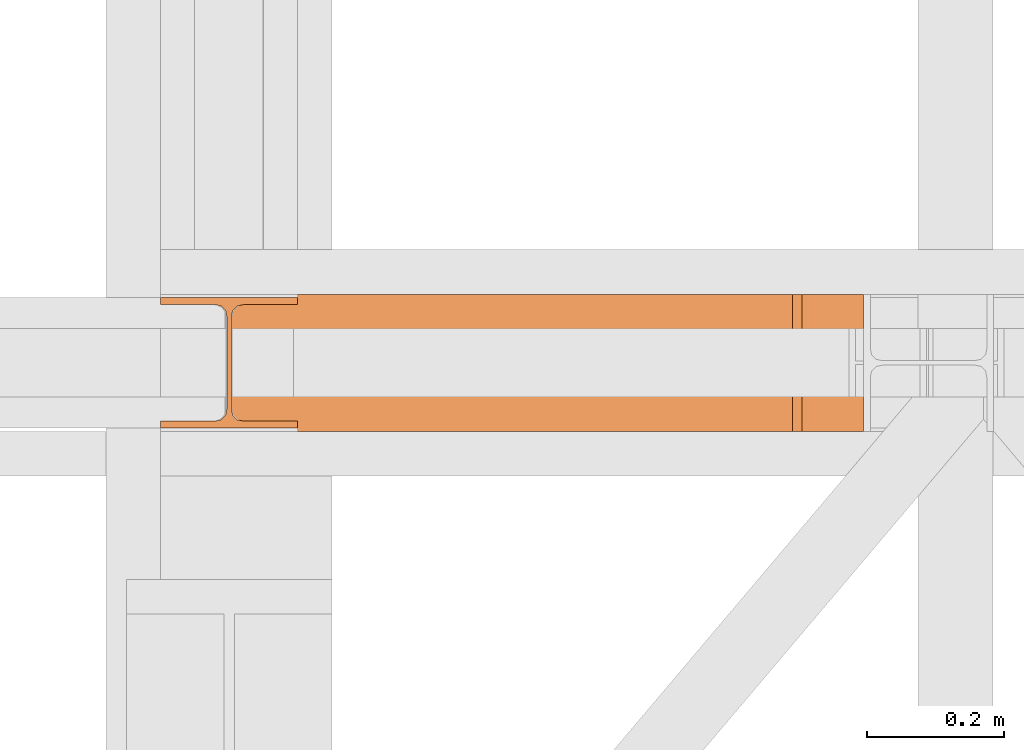
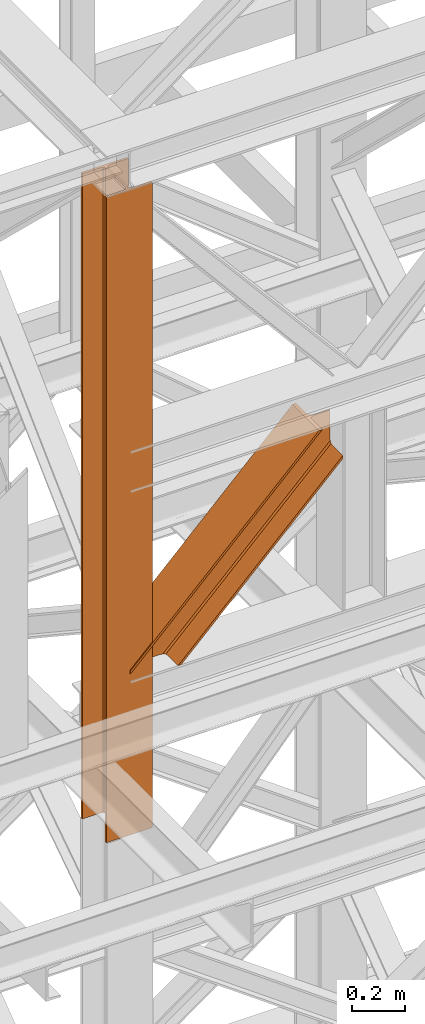
# One storey, part 107 of 208: 2 proxies.
"""IFC2X3 building model written with IfcOpenShell, lengths in millimetres."""

from ifc_helpers import new_model, entity, si_unit, converted_unit, frame, origin, origin_with_axes, place, context, subcontext, project, spatial, faceted_brep, element, save


model = new_model("IFC2X3")

# Units and contexts
model_context = context("Model", 3, precision=1e-05, world=origin())
plan_context = context("Plan", 3, precision=1e-05, world=origin())
body_context = subcontext(model_context, "Body", "Model", "MODEL_VIEW")
ifc_project = project(units=[si_unit("LENGTHUNIT", "METRE", prefix="MILLI"), converted_unit("PLANEANGLEUNIT", "DEGREE", entity("IfcPlaneAngleMeasure", 0.0174532925199433), si_unit("PLANEANGLEUNIT", "RADIAN"), dimensions=[0, 0, 0, 0, 0, 0, 0]), si_unit("AREAUNIT", "SQUARE_METRE"), si_unit("VOLUMEUNIT", "CUBIC_METRE")], contexts=[model_context, plan_context])

# Building, storey
building_placement = place(None, origin())
building = spatial("IfcBuilding", under=ifc_project, at=building_placement, CompositionType="COMPLEX")
storey_placement = place(building_placement, origin_with_axes())
storey = spatial("IfcBuildingStorey", under=building, at=storey_placement, Name="Geschoss", CompositionType="ELEMENT")

# Proxies
proxy_1_placement = place(storey_placement, frame((-4.776652347532718, -16062.574391808, 9993.99004617683), z_axis=(0.0, 0.0, 1.0), x_axis=(1.0, 0.0, 0.0)))
element("IfcBuildingElementProxy", 1, at=proxy_1_placement, inside=storey, context=body_context, shape_type="Brep", body=[
    faceted_brep([(220.8913571195315, 0.01000000000021828, 0.01000000000567525), (923.0416068691063, 0.01000000000021828, 700.1727607699759), (923.0416068691072, 200.0100029802325, 700.172760769974), (220.8913571195315, 200.0100029802325, 0.01000000000567525), (220.8913571195315, 200.0100029802325, 0.01000000000567525), (923.0416068691072, 200.0100029802325, 700.172760769974), (923.0416068691063, 200.0100029802325, 714.2845694178923), (206.7394905511699, 200.0100029802325, 0.01000000000385626), (206.7394905511699, 200.0100029802325, 0.01000000000385626), (923.0416068691063, 200.0100029802325, 714.2845694178923), (923.0416068691063, 121.2600035762789, 714.2845799320112), (206.7394800072068, 121.2600035762789, 0.01000000000385626), (206.7394800072068, 121.2600035762789, 0.01000000000385626), (923.0416068691063, 121.2600035762789, 714.2845799320112), (923.0416068691063, 111.9441915473344, 716.9157907731915), (204.1008001847456, 111.9441915473344, 0.01000000000203727), (204.1008001847456, 111.9441915473344, 0.01000000000203727), (923.0416068691063, 111.9441915473344, 716.9157907731915), (923.0416068691063, 105.1245498640838, 726.5395426003979), (194.4497302798461, 105.1245498640838, 0.01000000000385626), (194.4497302798461, 105.1245498640838, 0.01000000000385626), (923.0416068691063, 105.1245498640838, 726.5395426003979), (923.0416068691063, 103.2600015571716, 739.685839703905), (181.2661159665693, 103.2600015571716, 0.01000000000385626), (181.2661159665693, 103.2600015571716, 0.01000000000385626), (923.0416068691063, 103.2600015571716, 739.685839703905), (923.0416068691063, 103.2600015571716, 865.0100000000039), (859.0864467289928, 103.2600015571716, 865.0100000000039), (0.009999999999990905, 103.2600015571716, 8.365233628765054), (0.009999999999990905, 103.2600015571716, 0.01000000000385626), (0.009999999999990905, 103.2600015571716, 8.365233628765054), (859.0864467289928, 103.2600015571716, 865.0100000000039), (845.9028324157168, 105.1245498640838, 865.0100000000039), (0.009999999999990905, 105.1245498640838, 21.51153073227761), (0.009999999999990905, 105.1245498640838, 21.51153073227761), (845.9028324157168, 105.1245498640838, 865.0100000000039), (836.2517625108146, 111.9441915473344, 865.0100000000039), (0.009999999999990905, 111.9441915473344, 31.13528255948222), (0.009999999999990905, 111.9441915473344, 31.13528255948222), (836.2517625108146, 111.9441915473344, 865.0100000000039), (833.6130826883589, 121.2600035762789, 865.0100000000057), (0.009999999999990905, 121.2600035762789, 33.76649340066069), (0.009999999999990905, 121.2600035762789, 33.76649340066069), (833.6130826883589, 121.2600035762789, 865.0100000000057), (833.6130826883589, 200.0100029802325, 865.0100000000039), (0.009999999999990905, 200.0100029802325, 33.76649340066069), (0.009999999999990905, 200.0100029802325, 33.76649340066069), (833.6130826883589, 200.0100029802325, 865.0100000000039), (819.4612161199955, 200.0100029802325, 865.0100000000039), (0.009999999999990905, 200.0100029802325, 47.87830204857892), (0.009999999999990905, 200.0100029802325, 47.87830204857892), (819.4612161199955, 200.0100029802325, 865.0100000000039), (819.4612161199973, 0.01000000000021828, 865.0100000000057), (0.009999999999990905, 0.01000000000021828, 47.8783020485771), (0.009999999999990905, 0.01000000000021828, 47.8783020485771), (819.4612161199973, 0.01000000000021828, 865.0100000000057), (833.6130826883589, 0.01000000000021828, 865.0100000000039), (0.009999999999990905, 0.01000000000021828, 33.76649340066069), (0.009999999999990905, 0.01000000000021828, 33.76649340066069), (833.6130826883589, 0.01000000000021828, 865.0100000000039), (833.6130826883589, 78.75999940395377, 865.0100000000039), (0.009999999999990905, 78.75999940395377, 33.76649340066069), (0.009999999999990905, 78.75999940395377, 33.76649340066069), (833.6130826883589, 78.75999940395377, 865.0100000000039), (836.2517625108119, 88.07581143289826, 865.0100000000039), (0.009999999999990905, 88.07581143289826, 31.13528255948404), (0.009999999999990905, 88.07581143289826, 31.13528255948404), (836.2517625108119, 88.07581143289826, 865.0100000000039), (845.9028324157168, 94.89545311614893, 865.0100000000039), (0.009999999999990905, 94.89545311614893, 21.51153073227761), (0.009999999999990905, 94.89545311614893, 21.51153073227761), (845.9028324157168, 94.89545311614893, 865.0100000000039), (859.0864467289928, 96.76000142306111, 865.0100000000039), (0.009999999999990905, 96.76000142306111, 8.365233628765054), (0.009999999999990905, 96.76000142306111, 8.365233628765054), (859.0864467289928, 96.76000142306111, 865.0100000000039), (923.0416068691063, 96.76000142306111, 865.0100000000039), (923.0416068691063, 96.76000142306111, 739.685839703905), (181.2661159665693, 96.76000142306111, 0.01000000000385626), (0.009999999999990905, 96.76000142306111, 0.01000000000385626), (181.2661159665693, 96.76000142306111, 0.01000000000385626), (923.0416068691063, 96.76000142306111, 739.685839703905), (923.0416068691063, 94.89545311614893, 726.5395426003997), (194.4497302798461, 94.89545311614893, 0.01000000000385626), (194.4497302798461, 94.89545311614893, 0.01000000000385626), (923.0416068691063, 94.89545311614893, 726.5395426003997), (923.0416068691054, 88.07581143289826, 716.9157907731933), (204.1008001847474, 88.07581143289826, 0.01000000000385626), (204.1008001847474, 88.07581143289826, 0.01000000000385626), (923.0416068691054, 88.07581143289826, 716.9157907731933), (923.0416068691063, 78.75999940395377, 714.2845799320112), (206.7394800072032, 78.75999940395377, 0.01000000000021828), (206.7394800072032, 78.75999940395377, 0.01000000000021828), (923.0416068691063, 78.75999940395377, 714.2845799320112), (923.0416068691063, 0.01000000000021828, 714.2845694178923), (206.7394905511699, 0.01000000000021828, 0.01000000000203727), (206.7394905511699, 0.01000000000021828, 0.01000000000203727), (923.0416068691063, 0.01000000000021828, 714.2845694178923), (923.0416068691063, 0.01000000000021828, 700.1727607699759), (220.8913571195315, 0.01000000000021828, 0.01000000000567525), (220.8913571195315, 200.0100029802325, 0.01000000000567525), (206.7394905511699, 200.0100029802325, 0.01000000000385626), (206.7394800072068, 121.2600035762789, 0.01000000000385626), (204.1008001847456, 111.9441915473344, 0.01000000000203727), (194.4497302798461, 105.1245498640838, 0.01000000000385626), (181.2661159665693, 103.2600015571716, 0.01000000000385626), (0.009999999999990905, 103.2600015571716, 0.01000000000385626), (0.009999999999990905, 96.76000142306111, 0.01000000000385626), (181.2661159665693, 96.76000142306111, 0.01000000000385626), (194.4497302798461, 94.89545311614893, 0.01000000000385626), (204.1008001847474, 88.07581143289826, 0.01000000000385626), (206.7394800072032, 78.75999940395377, 0.01000000000021828), (206.7394905511699, 0.01000000000021828, 0.01000000000203727), (220.8913571195315, 0.01000000000021828, 0.01000000000567525), (0.009999999999990905, 103.2600015571716, 8.365233628765054), (0.009999999999990905, 105.1245498640838, 21.51153073227761), (0.009999999999990905, 111.9441915473344, 31.13528255948222), (0.009999999999990905, 121.2600035762789, 33.76649340066069), (0.009999999999990905, 200.0100029802325, 33.76649340066069), (0.009999999999990905, 200.0100029802325, 47.87830204857892), (0.009999999999990905, 0.01000000000021828, 47.8783020485771), (0.009999999999990905, 0.01000000000021828, 33.76649340066069), (0.009999999999990905, 78.75999940395377, 33.76649340066069), (0.009999999999990905, 88.07581143289826, 31.13528255948404), (0.009999999999990905, 94.89545311614893, 21.51153073227761), (0.009999999999990905, 96.76000142306111, 8.365233628765054), (0.009999999999990905, 96.76000142306111, 0.01000000000385626), (0.009999999999990905, 103.2600015571716, 0.01000000000385626), (923.0416068691063, 0.01000000000021828, 700.1727607699759), (923.0416068691063, 0.01000000000021828, 714.2845694178923), (923.0416068691063, 78.75999940395377, 714.2845799320112), (923.0416068691054, 88.07581143289826, 716.9157907731933), (923.0416068691063, 94.89545311614893, 726.5395426003997), (923.0416068691063, 96.76000142306111, 739.685839703905), (923.0416068691063, 96.76000142306111, 865.0100000000039), (923.0416068691063, 103.2600015571716, 865.0100000000039), (923.0416068691063, 103.2600015571716, 739.685839703905), (923.0416068691063, 105.1245498640838, 726.5395426003979), (923.0416068691063, 111.9441915473344, 716.9157907731915), (923.0416068691063, 121.2600035762789, 714.2845799320112), (923.0416068691063, 200.0100029802325, 714.2845694178923), (923.0416068691072, 200.0100029802325, 700.172760769974), (923.0416068691063, 103.2600015571716, 865.0100000000039), (923.0416068691063, 96.76000142306111, 865.0100000000039), (859.0864467289928, 96.76000142306111, 865.0100000000039), (845.9028324157168, 94.89545311614893, 865.0100000000039), (836.2517625108119, 88.07581143289826, 865.0100000000039), (833.6130826883589, 78.75999940395377, 865.0100000000039), (833.6130826883589, 0.01000000000021828, 865.0100000000039), (819.4612161199973, 0.01000000000021828, 865.0100000000057), (819.4612161199955, 200.0100029802325, 865.0100000000039), (833.6130826883589, 200.0100029802325, 865.0100000000039), (833.6130826883589, 121.2600035762789, 865.0100000000057), (836.2517625108146, 111.9441915473344, 865.0100000000039), (845.9028324157168, 105.1245498640838, 865.0100000000039), (859.0864467289928, 103.2600015571716, 865.0100000000039)], [[[0, 1, 2, 3]], [[4, 5, 6, 7]], [[8, 9, 10, 11]], [[12, 13, 14, 15]], [[16, 17, 18, 19]], [[20, 21, 22, 23]], [[24, 25, 26, 27, 28, 29]], [[30, 31, 32, 33]], [[34, 35, 36, 37]], [[38, 39, 40, 41]], [[42, 43, 44, 45]], [[46, 47, 48, 49]], [[50, 51, 52, 53]], [[54, 55, 56, 57]], [[58, 59, 60, 61]], [[62, 63, 64, 65]], [[66, 67, 68, 69]], [[70, 71, 72, 73]], [[74, 75, 76, 77, 78, 79]], [[80, 81, 82, 83]], [[84, 85, 86, 87]], [[88, 89, 90, 91]], [[92, 93, 94, 95]], [[96, 97, 98, 99]], [[100, 101, 102, 103, 104, 105, 106, 107, 108, 109, 110, 111, 112, 113]], [[114, 115, 116, 117, 118, 119, 120, 121, 122, 123, 124, 125, 126, 127]], [[128, 129, 130, 131, 132, 133, 134, 135, 136, 137, 138, 139, 140, 141]], [[142, 143, 144, 145, 146, 147, 148, 149, 150, 151, 152, 153, 154, 155]]], orient=[[False], [False], [False], [False], [False], [False], [False], [False], [False], [False], [False], [False], [False], [False], [False], [False], [False], [False], [False], [False], [False], [False], [False], [False], [False], [False], [False], [False]]),
])
proxy_2_placement = place(storey_placement, frame((-106.7450329614492, -16057.57439657637, 9284.990005364414), z_axis=(0.0, 0.0, 1.0), x_axis=(1.0, 0.0, 0.0)))
element("IfcBuildingElementProxy", 2, at=proxy_2_placement, inside=storey, context=body_context, shape_type="Brep", body=[
    faceted_brep([(0.01000000000000512, 190.0100125169756, 2965.010053329395), (200.0100029802322, 190.0100125169756, 2965.010053329395), (200.0100029802322, 180.0100146031382, 2965.010053329395), (121.2600035762787, 180.0100071525576, 2965.010053329395), (111.9441915473342, 178.1454621052744, 2965.010053329395), (105.1245498640835, 171.3258190250399, 2965.010053329395), (103.2600015571714, 162.010007927418, 2965.010053329395), (103.2600015571714, 28.00999713897727, 2965.010053329395), (105.1245498640835, 18.69418604135535, 2965.010053329395), (111.9441915473342, 11.87454296112082, 2965.010053329395), (121.2600035762787, 10.00999791383765, 2965.010053329395), (200.0100029802322, 10.00999791383765, 2965.010053329395), (200.0100029802322, 0.01000000000021828, 2965.010053329395), (0.01000000000000512, 0.01000000000021828, 2965.010053329395), (0.01000000000000512, 10.00999791383765, 2965.010053329395), (78.75999940395356, 10.00999791383765, 2965.010053329395), (88.07581143289805, 11.87454296112082, 2965.010053329395), (94.89545311614872, 18.69418604135535, 2965.010053329395), (96.7600014230609, 28.00999713897727, 2965.010053329395), (96.7600014230609, 162.010007927418, 2965.010053329395), (94.89545311614872, 171.3258190250399, 2965.010053329395), (88.07581143289805, 178.1454621052744, 2965.010053329395), (78.75999940395356, 180.0100071525576, 2965.010053329395), (0.01000000000000512, 180.0100146031382, 2965.010053329395), (200.0100029802322, 190.0100125169756, 2965.010053329395), (0.01000000000000512, 190.0100125169756, 2965.010053329395), (0.01000000000000512, 190.0100125169756, 0.01000000000021828), (200.0100029802322, 190.0100125169756, 0.01000000000021828), (200.0100029802322, 180.0100146031382, 2965.010053329395), (200.0100029802322, 190.0100125169756, 2965.010053329395), (200.0100029802322, 190.0100125169756, 0.01000000000021828), (200.0100029802322, 180.0100146031382, 0.01000000000021828), (121.2600035762787, 180.0100071525576, 2965.010053329395), (200.0100029802322, 180.0100146031382, 2965.010053329395), (200.0100029802322, 180.0100146031382, 0.01000000000021828), (121.2600035762787, 180.0100071525576, 0.01000000000021828), (111.9441915473342, 178.1454621052744, 2965.010053329395), (121.2600035762787, 180.0100071525576, 2965.010053329395), (121.2600035762787, 180.0100071525576, 0.01000000000021828), (111.9441915473342, 178.1454621052744, 0.01000000000021828), (105.1245498640835, 171.3258190250399, 2965.010053329395), (111.9441915473342, 178.1454621052744, 2965.010053329395), (111.9441915473342, 178.1454621052744, 0.01000000000021828), (105.1245498640835, 171.3258190250399, 0.01000000000021828), (103.2600015571714, 162.010007927418, 2965.010053329395), (105.1245498640835, 171.3258190250399, 2965.010053329395), (105.1245498640835, 171.3258190250399, 0.01000000000021828), (103.2600015571714, 162.010007927418, 0.01000000000021828), (103.2600015571714, 28.00999713897727, 2965.010053329395), (103.2600015571714, 162.010007927418, 2965.010053329395), (103.2600015571714, 162.010007927418, 0.01000000000021828), (103.2600015571714, 28.00999713897727, 0.01000000000021828), (105.1245498640835, 18.69418604135535, 2965.010053329395), (103.2600015571714, 28.00999713897727, 2965.010053329395), (103.2600015571714, 28.00999713897727, 0.01000000000021828), (105.1245498640835, 18.69418604135535, 0.01000000000021828), (111.9441915473342, 11.87454296112082, 2965.010053329395), (105.1245498640835, 18.69418604135535, 2965.010053329395), (105.1245498640835, 18.69418604135535, 0.01000000000021828), (111.9441915473342, 11.87454296112082, 0.01000000000021828), (121.2600035762787, 10.00999791383765, 2965.010053329395), (111.9441915473342, 11.87454296112082, 2965.010053329395), (111.9441915473342, 11.87454296112082, 0.01000000000021828), (121.2600035762787, 10.00999791383765, 0.01000000000021828), (200.0100029802322, 10.00999791383765, 2965.010053329395), (121.2600035762787, 10.00999791383765, 2965.010053329395), (121.2600035762787, 10.00999791383765, 0.01000000000021828), (200.0100029802322, 10.00999791383765, 0.01000000000021828), (200.0100029802322, 0.01000000000021828, 2965.010053329395), (200.0100029802322, 10.00999791383765, 2965.010053329395), (200.0100029802322, 10.00999791383765, 0.01000000000021828), (200.0100029802322, 0.01000000000021828, 0.01000000000021828), (0.01000000000000512, 0.01000000000021828, 2965.010053329395), (200.0100029802322, 0.01000000000021828, 2965.010053329395), (200.0100029802322, 0.01000000000021828, 0.01000000000021828), (0.01000000000000512, 0.01000000000021828, 0.01000000000021828), (0.01000000000000512, 10.00999791383765, 2965.010053329395), (0.01000000000000512, 0.01000000000021828, 2965.010053329395), (0.01000000000000512, 0.01000000000021828, 0.01000000000021828), (0.01000000000000512, 10.00999791383765, 0.01000000000021828), (78.75999940395356, 10.00999791383765, 2965.010053329395), (0.01000000000000512, 10.00999791383765, 2965.010053329395), (0.01000000000000512, 10.00999791383765, 0.01000000000021828), (78.75999940395356, 10.00999791383765, 0.01000000000021828), (88.07581143289805, 11.87454296112082, 2965.010053329395), (78.75999940395356, 10.00999791383765, 2965.010053329395), (78.75999940395356, 10.00999791383765, 0.01000000000021828), (88.07581143289805, 11.87454296112082, 0.01000000000021828), (94.89545311614872, 18.69418604135535, 2965.010053329395), (88.07581143289805, 11.87454296112082, 2965.010053329395), (88.07581143289805, 11.87454296112082, 0.01000000000021828), (94.89545311614872, 18.69418604135535, 0.01000000000021828), (96.7600014230609, 28.00999713897727, 2965.010053329395), (94.89545311614872, 18.69418604135535, 2965.010053329395), (94.89545311614872, 18.69418604135535, 0.01000000000021828), (96.7600014230609, 28.00999713897727, 0.01000000000021828), (96.7600014230609, 162.010007927418, 2965.010053329395), (96.7600014230609, 28.00999713897727, 2965.010053329395), (96.7600014230609, 28.00999713897727, 0.01000000000021828), (96.7600014230609, 162.010007927418, 0.01000000000021828), (94.89545311614872, 171.3258190250399, 2965.010053329395), (96.7600014230609, 162.010007927418, 2965.010053329395), (96.7600014230609, 162.010007927418, 0.01000000000021828), (94.89545311614872, 171.3258190250399, 0.01000000000021828), (88.07581143289805, 178.1454621052744, 2965.010053329395), (94.89545311614872, 171.3258190250399, 2965.010053329395), (94.89545311614872, 171.3258190250399, 0.01000000000021828), (88.07581143289805, 178.1454621052744, 0.01000000000021828), (78.75999940395356, 180.0100071525576, 2965.010053329395), (88.07581143289805, 178.1454621052744, 2965.010053329395), (88.07581143289805, 178.1454621052744, 0.01000000000021828), (78.75999940395356, 180.0100071525576, 0.01000000000021828), (0.01000000000000512, 180.0100146031382, 2965.010053329395), (78.75999940395356, 180.0100071525576, 2965.010053329395), (78.75999940395356, 180.0100071525576, 0.01000000000021828), (0.01000000000000512, 180.0100146031382, 0.01000000000021828), (0.01000000000000512, 190.0100125169756, 2965.010053329395), (0.01000000000000512, 180.0100146031382, 2965.010053329395), (0.01000000000000512, 180.0100146031382, 0.01000000000021828), (0.01000000000000512, 190.0100125169756, 0.01000000000021828), (0.01000000000000512, 190.0100125169756, 0.01000000000021828), (0.01000000000000512, 180.0100146031382, 0.01000000000021828), (78.75999940395356, 180.0100071525576, 0.01000000000021828), (88.07581143289805, 178.1454621052744, 0.01000000000021828), (94.89545311614872, 171.3258190250399, 0.01000000000021828), (96.7600014230609, 162.010007927418, 0.01000000000021828), (96.7600014230609, 28.00999713897727, 0.01000000000021828), (94.89545311614872, 18.69418604135535, 0.01000000000021828), (88.07581143289805, 11.87454296112082, 0.01000000000021828), (78.75999940395356, 10.00999791383765, 0.01000000000021828), (0.01000000000000512, 10.00999791383765, 0.01000000000021828), (0.01000000000000512, 0.01000000000021828, 0.01000000000021828), (200.0100029802322, 0.01000000000021828, 0.01000000000021828), (200.0100029802322, 10.00999791383765, 0.01000000000021828), (121.2600035762787, 10.00999791383765, 0.01000000000021828), (111.9441915473342, 11.87454296112082, 0.01000000000021828), (105.1245498640835, 18.69418604135535, 0.01000000000021828), (103.2600015571714, 28.00999713897727, 0.01000000000021828), (103.2600015571714, 162.010007927418, 0.01000000000021828), (105.1245498640835, 171.3258190250399, 0.01000000000021828), (111.9441915473342, 178.1454621052744, 0.01000000000021828), (121.2600035762787, 180.0100071525576, 0.01000000000021828), (200.0100029802322, 180.0100146031382, 0.01000000000021828), (200.0100029802322, 190.0100125169756, 0.01000000000021828)], [[[0, 1, 2, 3, 4, 5, 6, 7, 8, 9, 10, 11, 12, 13, 14, 15, 16, 17, 18, 19, 20, 21, 22, 23]], [[24, 25, 26, 27]], [[28, 29, 30, 31]], [[32, 33, 34, 35]], [[36, 37, 38, 39]], [[40, 41, 42, 43]], [[44, 45, 46, 47]], [[48, 49, 50, 51]], [[52, 53, 54, 55]], [[56, 57, 58, 59]], [[60, 61, 62, 63]], [[64, 65, 66, 67]], [[68, 69, 70, 71]], [[72, 73, 74, 75]], [[76, 77, 78, 79]], [[80, 81, 82, 83]], [[84, 85, 86, 87]], [[88, 89, 90, 91]], [[92, 93, 94, 95]], [[96, 97, 98, 99]], [[100, 101, 102, 103]], [[104, 105, 106, 107]], [[108, 109, 110, 111]], [[112, 113, 114, 115]], [[116, 117, 118, 119]], [[120, 121, 122, 123, 124, 125, 126, 127, 128, 129, 130, 131, 132, 133, 134, 135, 136, 137, 138, 139, 140, 141, 142, 143]]], orient=[[False], [False], [False], [False], [False], [False], [False], [False], [False], [False], [False], [False], [False], [False], [False], [False], [False], [False], [False], [False], [False], [False], [False], [False], [False], [False]]),
])

save(model, "model.ifc")
